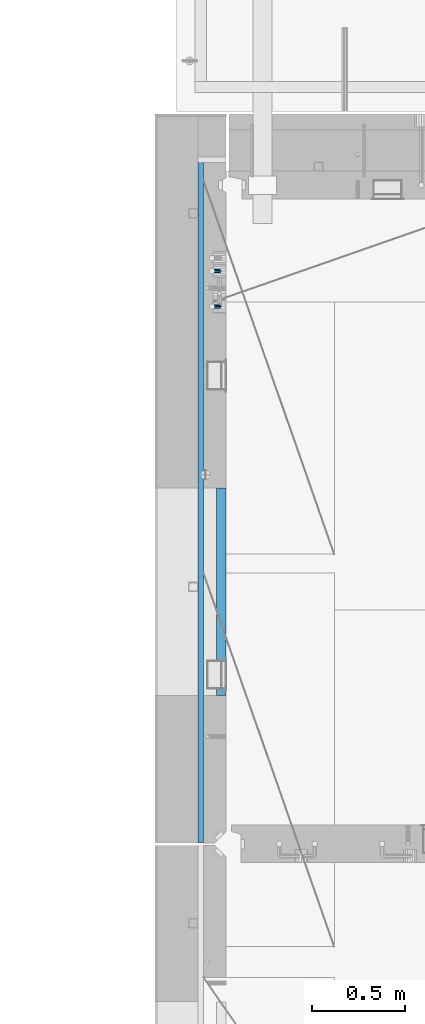
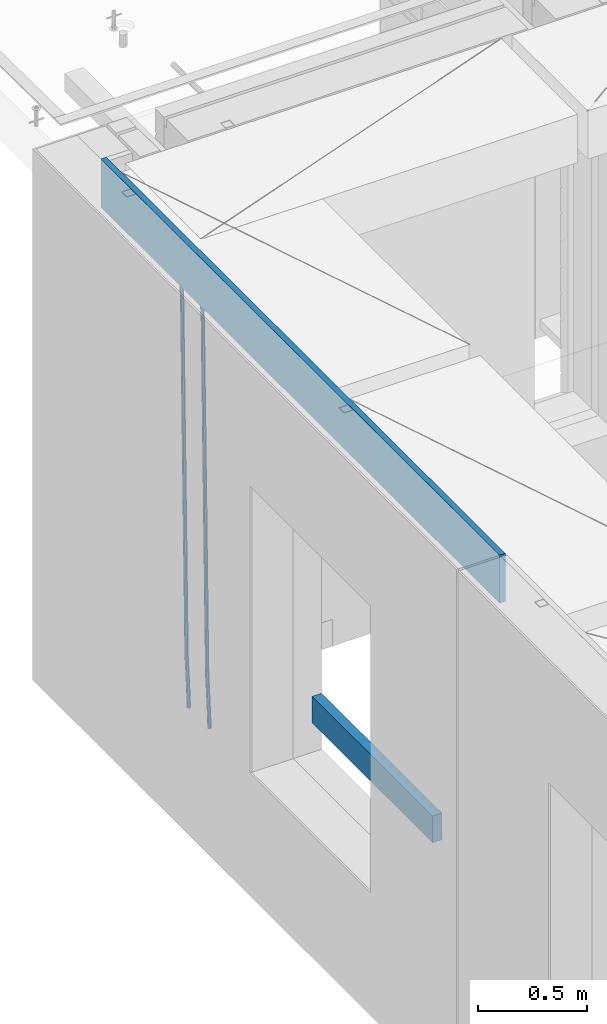
# One storey, part 113 of 349: 4 beams, 1 element without a shape of its own.
"""IFC2X3 building model written with IfcOpenShell, lengths in millimetres."""

import ifcopenshell
import ifcopenshell.guid

model = None  # the IFC model being written
_history = None  # IfcOwnerHistory: only IFC2X3 demands one
_inside = {}  # id of a spatial element -> (the spatial element, [elements in it])
_under = {}  # id of a project, library or spatial element -> (it, [spatial elements below it])
_declared = {}  # id of a project -> (the project, [libraries it declares])
_typed = {}  # id of a type object -> (the type object, [elements of that type])
_made_of = {}  # id of a material, layer set ... -> (it, [elements and type objects made of it])


def new_model(schema):
    """Start an empty IFC model of exactly this schema.

    Asked for "IFC4X3", IfcOpenShell would pick the latest addendum, in which some entities
    have other attributes; the version numbers below select the first issue.
    IFC2X3 requires an IfcOwnerHistory on every rooted entity: one is made here for all.
    """
    global model, _history
    if schema == "IFC4X3":
        model = ifcopenshell.file(schema_version=(4, 3, 0, 0))
    else:
        model = ifcopenshell.file(schema=schema)
    _inside.clear()
    _under.clear()
    _declared.clear()
    _typed.clear()
    _made_of.clear()
    _history = None
    if model.schema == "IFC2X3":
        org = make("IfcOrganization", Name="unknown")
        user = make(
            "IfcPersonAndOrganization",
            ThePerson=make("IfcPerson", FamilyName="unknown"),
            TheOrganization=org,
        )
        app = make(
            "IfcApplication",
            ApplicationDeveloper=org,
            Version="unknown",
            ApplicationFullName="unknown",
            ApplicationIdentifier="unknown",
        )
        _history = make(
            "IfcOwnerHistory",
            OwningUser=user,
            OwningApplication=app,
            ChangeAction="ADDED",
            CreationDate=0,
        )
    return model


def make(cls, **values):
    """One entity of the class cls with the attributes given. An attribute that is None is left unset."""
    return model.create_entity(
        cls, **{name: value for name, value in values.items() if value is not None}
    )


def rooted(cls, **values):
    """An entity with a GlobalId (a new one), such as an element, a storey or a relation."""
    return make(cls, GlobalId=ifcopenshell.guid.new(), OwnerHistory=_history, **values)


def si_unit(unit_type, name, prefix=None):
    """IfcSIUnit, for example si_unit("LENGTHUNIT", "METRE", prefix="MILLI")."""
    return make("IfcSIUnit", UnitType=unit_type, Prefix=prefix, Name=name)


def assignment(units):
    """IfcUnitAssignment: the units of a project."""
    return None if units is None else make("IfcUnitAssignment", Units=units)


def point(xyz):
    """IfcCartesianPoint."""
    return None if xyz is None else make("IfcCartesianPoint", Coordinates=xyz)


def direction(xyz):
    """IfcDirection."""
    return None if xyz is None else make("IfcDirection", DirectionRatios=xyz)


def frame(location, z_axis=None, x_axis=None):
    """IfcAxis2Placement3D, a coordinate frame: its origin and axes. An axis left out is left unset."""
    return make(
        "IfcAxis2Placement3D",
        Location=point(location),
        Axis=direction(z_axis),
        RefDirection=direction(x_axis),
    )


def origin_with_axes():
    """The frame at (0, 0, 0) with the z axis (0, 0, 1) and the x axis (1, 0, 0) written out."""
    return frame((0.0, 0.0, 0.0), z_axis=(0.0, 0.0, 1.0), x_axis=(1.0, 0.0, 0.0))


def place(relative_to, where):
    """IfcLocalPlacement: puts the frame where relative to a parent placement (None: the world)."""
    return make(
        "IfcLocalPlacement", PlacementRelTo=relative_to, RelativePlacement=where
    )


def context(
    kind, dimensions, precision=None, world=None, true_north=None, identifier=None
):
    """IfcGeometricRepresentationContext, for example the 3D "Model" context."""
    return make(
        "IfcGeometricRepresentationContext",
        ContextIdentifier=identifier,
        ContextType=kind,
        CoordinateSpaceDimension=dimensions,
        Precision=precision,
        WorldCoordinateSystem=world,
        TrueNorth=true_north,
    )


def subcontext(parent, identifier, kind, view, scale=None):
    """IfcGeometricRepresentationSubContext, for example "Body" below "Model"."""
    return make(
        "IfcGeometricRepresentationSubContext",
        ContextIdentifier=identifier,
        ContextType=kind,
        ParentContext=parent,
        TargetScale=scale,
        TargetView=view,
    )


def project(units=None, contexts=None):
    """IfcProject with its units and contexts."""
    return rooted(
        "IfcProject",
        Name="project",
        RepresentationContexts=contexts,
        UnitsInContext=assignment(units),
    )


def spatial(cls, under=None, at=None, **own):
    """A site, building, storey or space (cls), placed at a placement, below another one or the project."""
    s = rooted(cls, ObjectPlacement=at, **own)
    if under is not None:
        _under.setdefault(under.id(), (under, []))[1].append(s)
    return s


def faces_of(points, faces, orient=None, outer=None):
    """IfcFace entities. A face is a list of loops; a loop is a list of indices into points, from 0.

    orient and outer hold one flag for each loop. By default every Orientation is true, the
    first loop of a face is its IfcFaceOuterBound and the others are IfcFaceBound.
    """
    made = []
    for i, loops in enumerate(faces):
        bounds = []
        for j, loop in enumerate(loops):
            is_outer = j == 0 if outer is None else outer[i][j]
            bounds.append(
                make(
                    "IfcFaceOuterBound" if is_outer else "IfcFaceBound",
                    Bound=make("IfcPolyLoop", Polygon=[points[k] for k in loop]),
                    Orientation=True if orient is None else orient[i][j],
                )
            )
        made.append(make("IfcFace", Bounds=bounds))
    return made


def faceted_brep(points, faces, orient=None, outer=None, voids=None):
    """IfcFacetedBrep: a solid bounded by flat faces; with voids (closed shells), ...WithVoids."""
    shared = [point(p) for p in points]
    hull = make("IfcClosedShell", CfsFaces=faces_of(shared, faces, orient, outer))
    if voids is None:
        return make("IfcFacetedBrep", Outer=hull)
    return make(
        "IfcFacetedBrepWithVoids",
        Outer=hull,
        Voids=[
            make(cls, CfsFaces=faces_of(shared, fs, o, b)) for cls, fs, o, b in voids
        ],
    )


def shape(context_of_items, identifier, shape_type, items):
    """IfcShapeRepresentation: the items that make up one representation, for example the "Body"."""
    return make(
        "IfcShapeRepresentation",
        ContextOfItems=context_of_items,
        RepresentationIdentifier=identifier,
        RepresentationType=shape_type,
        Items=items,
    )


def material(Name=None, Category=None):
    """IfcMaterial."""
    return make("IfcMaterial", Name=Name, Category=Category)


def made_of(thing, what):
    """Note that an element or type object is made of a material, layer set ...; save() writes the relation."""
    if what is not None:
        _made_of.setdefault(what.id(), (what, []))[1].append(thing)
    return thing


def type_object(cls, material=None, **own):
    """A type object (cls), such as IfcWallType, which elements share."""
    return made_of(rooted(cls, **own), material)


def element(
    cls,
    number,
    at=None,
    inside=None,
    cuts=None,
    type_object=None,
    material=None,
    context=None,
    identifier="Body",
    shape_type=None,
    held_by="IfcProductDefinitionShape",
    body=None,
    shapes=None,
    **own,
):
    """One element of the class cls, such as IfcWall. Its Tag is "e" and its number.

    at: its placement. inside: the storey or other place that contains it. cuts: it is an
    opening in that element (IfcRelVoidsElement). A single representation is given by context,
    identifier, shape_type and body (its items); several are given by shapes. held_by: the class
    of the entity that holds the representations. save() writes the other relations.
    """
    e = rooted(cls, Tag="e%d" % number, ObjectPlacement=at, **own)
    if body is not None:
        shapes = [shape(context, identifier, shape_type, body)]
    if shapes is not None:
        e.Representation = make(held_by, Representations=shapes)
    if inside is not None:
        _inside.setdefault(inside.id(), (inside, []))[1].append(e)
    if cuts is not None:
        rooted(
            "IfcRelVoidsElement", RelatingBuildingElement=cuts, RelatedOpeningElement=e
        )
    if type_object is not None:
        _typed.setdefault(type_object.id(), (type_object, []))[1].append(e)
    return made_of(e, material)


def aggregate(whole, parts):
    """IfcRelAggregates: a whole, such as a stair, and the parts it consists of."""
    return rooted("IfcRelAggregates", RelatingObject=whole, RelatedObjects=parts)


def save(model, path):
    """Write the relations noted so far, then the file.

    IfcRelAggregates (storeys below a building ...), IfcRelContainedInSpatialStructure (elements
    in a storey), IfcRelDefinesByType, IfcRelAssociatesMaterial and IfcRelDeclares: one each for
    every whole, place, type object, material and project.
    """
    for whole, parts in _under.values():
        aggregate(whole, parts)
    for where, things in _inside.values():
        rooted(
            "IfcRelContainedInSpatialStructure",
            RelatedElements=things,
            RelatingStructure=where,
        )
    for kind, things in _typed.values():
        rooted("IfcRelDefinesByType", RelatedObjects=things, RelatingType=kind)
    for what, things in _made_of.values():
        rooted("IfcRelAssociatesMaterial", RelatedObjects=things, RelatingMaterial=what)
    for by, libraries in _declared.values():
        rooted("IfcRelDeclares", RelatingContext=by, RelatedDefinitions=libraries)
    model.write(path)


model = new_model("IFC2X3")

# Units and contexts
model_context = context("Model", 3, precision=1e-05, world=origin_with_axes())
body_context = subcontext(model_context, "Body", "Model", "MODEL_VIEW")
ifc_project = project(units=[si_unit("LENGTHUNIT", "METRE", prefix="MILLI"), si_unit("AREAUNIT", "SQUARE_METRE"), si_unit("VOLUMEUNIT", "CUBIC_METRE"), si_unit("MASSUNIT", "GRAM", prefix="KILO"), si_unit("TIMEUNIT", "SECOND"), si_unit("PLANEANGLEUNIT", "RADIAN"), si_unit("SOLIDANGLEUNIT", "STERADIAN"), si_unit("THERMODYNAMICTEMPERATUREUNIT", "DEGREE_CELSIUS"), si_unit("LUMINOUSINTENSITYUNIT", "LUMEN")], contexts=[model_context])

# Site, building, storey
site_placement = place(None, origin_with_axes())
site = spatial("IfcSite", under=ifc_project, at=site_placement, CompositionType="ELEMENT")
building_placement = place(site_placement, origin_with_axes())
building = spatial("IfcBuilding", under=site, at=building_placement, CompositionType="ELEMENT")
storey_placement = place(building_placement, origin_with_axes())
storey = spatial("IfcBuildingStorey", under=building, at=storey_placement, Name="4", CompositionType="ELEMENT", Elevation=0.0)

# Assembly, beams
assembly_placement = place(storey_placement, origin_with_axes())
assembly = element("IfcElementAssembly", 1, at=assembly_placement, inside=storey, AssemblyPlace="NOTDEFINED", PredefinedType="REINFORCEMENT_UNIT")
ifc_material_1 = material()
beam_type_1 = type_object("IfcBeamType", Name="D20", PredefinedType="NOTDEFINED")
beam_1_placement = place(assembly_placement, frame((7965.00000227913, 19854.9969072611, 90990.0), z_axis=(-0.999642804636942, -0.000205726999925762, -0.0267249099902983), x_axis=(-0.0267249099948371, 4.30000201934385e-08, 0.999642825806181)))
beam_1 = element("IfcBeam", 2, at=beam_1_placement, type_object=beam_type_1, material=ifc_material_1, Name="JM20", ObjectType="D20", context=body_context, shape_type="Brep", body=[
    faceted_brep([(0.0, -10.0, 0.0), (-4.19531716033816e-08, -7.07106781186667, -7.07106781187031), (60.4266690400545, -7.0710677960451, -7.07106780570757), (60.4266690441291, -9.99999998418934, 6.15546014159918e-09), (0.0, 0.0, -10.0), (60.426669036824, 1.58106558956206e-08, -9.99999999384454), (4.196772351861e-08, 7.07106781186303, -7.07106781186667), (60.4266690363438, 7.07106782768096, -7.07106780570757), (0.0, 10.0, 0.0), (60.4266690388904, 10.0000000158179, 6.15182216279209e-09), (4.196772351861e-08, 7.07106781185939, 7.07106781185939), (60.4266690429649, 7.07106782768096, 7.07106781802577), (0.0, 0.0, 10.0), (60.4266690461809, 1.58179318532348e-08, 10.0000000061555), (-4.19531716033816e-08, -7.07106781187031, 7.07106781185939), (60.4266690466611, -7.07106779605238, 7.07106781802213), (61.0378400410118, -7.07106779588503, -7.07106780564936), (60.991799419251, -9.99999998403655, 6.21366780251265e-09), (61.0569027789461, 1.5985278878361e-08, -9.99999999378269), (61.0378209396877, 7.07106782784831, -7.07106780564936), (60.9917724058905, 10.0000000159635, 6.21366780251265e-09), (60.9457317841297, 7.07106782781193, 7.0710678180767), (60.9266690461809, 1.59488990902901e-08, 10.0000000062028), (60.9457508854539, -7.07106779591413, 7.0710678180767), (61.6489592143771, -7.07106614513759, -7.06310863441468), (61.5568818710308, -9.9999984576425, 0.00735959856683621), (61.6870830769039, 1.71821739058942e-06, -9.99179257185824), (61.6489210170112, 7.07106947854481, -7.06310888312146), (61.556827851804, 10.0000015422847, 0.00735924683976918), (61.4647505084577, 7.07106922979438, 7.07782747982128), (61.4266266459163, 1.36643211590126e-06, 10.0065114172685), (61.464788705809, -7.07106639389531, 7.07782772852806), (176.543135720174, -7.07075579406956, -5.56673531796696), (176.451058376813, -9.99968810657447, 1.50373291501455), (176.581259582701, 0.000312069292704109, -8.49541925541052), (176.543097522794, 7.07137982961285, -5.56673556667374), (176.451004357587, 10.00031189336, 1.50373256329476), (176.35892701424, 7.07137958085514, 8.57420079627263), (176.320803151699, 0.000311717507429421, 11.5028847337162), (176.358965211621, -7.07075604281999, 8.57420104497578), (177.098753836006, -7.07075429323595, -5.55949898843028), (176.98362511232, -9.99968666800123, 1.510669025065), (177.146421932586, 0.000313595905026887, -8.48805862247536), (177.098706077581, 7.07138133041735, -5.55949936166144), (176.983557571715, 10.0003133318824, 1.51066849724157), (176.868428848029, 7.07138095712435, 8.58083651073321), (176.820760751449, 0.000313067976094317, 11.5093961447819), (176.868476606425, -7.07075466652896, 8.58083688396073), (177.654312950661, -7.07075204110879, -5.54863964998367), (177.516135294456, -9.99968450931192, 1.52107783331303), (177.711524267797, 0.000315886711177882, -8.47701274570863), (177.654255632195, 7.07138358250813, -5.54864021007961), (177.516054233929, 10.0003154905207, 1.5210770412159), (177.377876577739, 7.0713830223176, 8.59079452451624), (177.320665260588, 0.000315094497636892, 11.5191676202448), (177.377933896176, -7.07075260129932, 8.59079508461218), (299.436796249574, -7.07025836271714, -3.1681962331204), (299.298618593355, -9.99919083092027, 3.90152125031091), (299.494007566798, 0.000809565110102994, -6.09656932889993), (299.436738931283, 7.07187726089978, -3.16819679320906), (299.298537533061, 10.0008091689197, 3.90152045822106), (299.160359876842, 7.07187670072017, 10.9712379416487), (299.103148559603, 0.000808772889286047, 13.8996110374392), (299.160417195119, -7.07025892290039, 10.9712385017483), (299.98743051647, -7.07025613056248, -3.15743315966392), (299.971788958996, -9.99918809853989, 3.91467979818117), (299.993912075952, 0.000811591617093654, -6.08679785393178), (299.987423933868, 7.07187949325817, -3.1574327280432), (299.971753863239, 10.0008119014747, 3.91467990454839), (299.95611230444, 7.07187992653053, 10.9867922621015), (299.949630744944, 0.000812204350950196, 13.9161569563694), (299.956118887014, -7.07025569729012, 10.9867918304735), (300.538107039494, -7.07025785017686, -3.16575821840888), (300.644985195438, -9.99919020432935, 3.90450175465594), (300.493854948218, 0.000810030429420294, -6.09435592770024), (300.538151196495, 7.071877773491, -3.16575855385963), (300.645047642858, 10.0008097955724, 3.90450128024895), (300.751925798773, 7.07187744142357, 10.9747612533101), (300.796177890064, 0.000809560813650023, 13.9033589625978), (300.751881641787, -7.07025818224065, 10.9747615887682), (2293.36490490142, -7.07648090940347, -33.2930642912361), (2293.47178305736, -10.0054132635523, -26.2228043181785), (2293.32065281013, -0.00541302880083094, -36.2216620005347), (2293.36494905842, 7.06565471425711, -33.2930646266868), (2293.47184550477, 9.99458673634581, -26.2228047925819), (2293.57872366071, 7.06565438219332, -19.1525448195243), (2293.62297575199, -0.00541349841296324, -16.2239471102366), (2293.57867950371, -7.0764812414709, -19.1525444840736), (2294.0658245362, -7.07648309818615, -33.3036607065333), (2294.05312277409, -10.0054150789219, -26.2315929392535), (2294.10928714235, -0.00541549149056664, -36.2335844756526), (2294.15805078732, 7.06565223761572, -33.3050546393533), (2294.18355038921, 9.99458451388637, -26.2335642579346), (2294.17084862708, 7.06565253314329, -19.1614964906439), (2294.12738602093, -0.00541507354500936, -16.2315727215355), (2294.07862237596, -7.07648280265857, -19.1601025578348), (2294.76670261032, -7.08562269121467, -33.294332712383), (2294.63442802057, -10.0129954178956, -26.2238563411993), (2294.89787471293, -0.0156988342423574, -36.2230891548279), (2294.95110548967, 7.05531064255774, -33.2944998654275), (2294.89521307347, 9.98530428734011, -26.2240927312887), (2294.76293848372, 7.0579315606592, -19.1536163601049), (2294.63176638114, -0.0119922963167483, -16.2248599176673), (2294.57853560438, -7.08300177311321, -19.1534492070678), (2316.52657204497, -7.36937582653991, -33.0047303660212), (2316.39429745522, -10.2967485532172, -25.9342539948302), (2316.65774414754, -0.299451969567599, -35.9334868084661), (2316.7109749243, 6.7715575072325, -33.0048975190657), (2316.65508250811, 9.70155115201487, -25.9344903849269), (2316.52280791836, 6.7741784253376, -18.8640140137468), (2316.39163581574, -0.295745431634714, -15.9352575713092), (2316.33840503903, -7.36675490843481, -18.863846860706), (2317.16202064224, -7.37766220584308, -32.9962731735213), (2317.05438744847, -10.3053562613532, -25.9254688497131), (2317.23607125619, -0.306993473008333, -35.925789846493), (2317.23316144495, 6.76474808850253, -32.9979477328052), (2317.15499573652, 9.6950321815566, -25.9278370341635), (2317.04736254275, 6.7673381260538, -18.8570327103698), (2316.97331192881, -0.303330606784584, -15.9275160373909), (2316.97622174003, -7.37507216829545, -18.8553581510787), (2317.79752306276, -7.37578610372293, -32.9880110666527), (2317.71453320107, -10.3033876998124, -25.9168792378296), (2317.81444760226, -0.305295583297266, -35.918287695793), (2317.75539265381, 6.76628640723357, -32.9911928173897), (2317.65495180529, 9.69652304524061, -25.9213789128698), (2317.5719619436, 6.76892144914746, -18.8502470840467), (2317.55503740412, -0.301569071270933, -15.9199704549137), (2317.61409235255, -7.3731510618054, -18.847065333317), (2417.8183084176, -7.07752398473531, -31.6906369377139), (2417.73531855589, -10.0051255808248, -24.6195051088798), (2417.83523295709, -0.007033464313281, -34.6209135668432), (2417.77617800863, 7.06454852621755, -31.6938186884508), (2417.67573716014, 9.99478516423187, -24.6240047839383), (2417.59274729842, 7.06718356813872, -17.5528729551006), (2417.57582275895, -0.00330695228694822, -14.6225963259749), (2417.6348777074, -7.07488894281778, -17.5496912043673)], [[[0, 1, 2, 3]], [[1, 4, 5, 2]], [[4, 6, 7, 5]], [[6, 8, 9, 7]], [[8, 10, 11, 9]], [[10, 12, 13, 11]], [[12, 14, 15, 13]], [[14, 0, 3, 15]], [[14, 12, 10, 8, 6, 4, 1, 0]], [[3, 2, 16, 17]], [[2, 5, 18, 16]], [[5, 7, 19, 18]], [[7, 9, 20, 19]], [[9, 11, 21, 20]], [[11, 13, 22, 21]], [[13, 15, 23, 22]], [[15, 3, 17, 23]], [[17, 16, 24, 25]], [[16, 18, 26, 24]], [[18, 19, 27, 26]], [[19, 20, 28, 27]], [[20, 21, 29, 28]], [[21, 22, 30, 29]], [[22, 23, 31, 30]], [[23, 17, 25, 31]], [[25, 24, 32, 33]], [[24, 26, 34, 32]], [[26, 27, 35, 34]], [[27, 28, 36, 35]], [[28, 29, 37, 36]], [[29, 30, 38, 37]], [[30, 31, 39, 38]], [[31, 25, 33, 39]], [[33, 32, 40, 41]], [[32, 34, 42, 40]], [[34, 35, 43, 42]], [[35, 36, 44, 43]], [[36, 37, 45, 44]], [[37, 38, 46, 45]], [[38, 39, 47, 46]], [[39, 33, 41, 47]], [[41, 40, 48, 49]], [[40, 42, 50, 48]], [[42, 43, 51, 50]], [[43, 44, 52, 51]], [[44, 45, 53, 52]], [[45, 46, 54, 53]], [[46, 47, 55, 54]], [[47, 41, 49, 55]], [[49, 48, 56, 57]], [[48, 50, 58, 56]], [[50, 51, 59, 58]], [[51, 52, 60, 59]], [[52, 53, 61, 60]], [[53, 54, 62, 61]], [[54, 55, 63, 62]], [[55, 49, 57, 63]], [[57, 56, 64, 65]], [[56, 58, 66, 64]], [[58, 59, 67, 66]], [[59, 60, 68, 67]], [[60, 61, 69, 68]], [[61, 62, 70, 69]], [[62, 63, 71, 70]], [[63, 57, 65, 71]], [[65, 64, 72, 73]], [[64, 66, 74, 72]], [[66, 67, 75, 74]], [[67, 68, 76, 75]], [[68, 69, 77, 76]], [[69, 70, 78, 77]], [[70, 71, 79, 78]], [[71, 65, 73, 79]], [[73, 72, 80, 81]], [[72, 74, 82, 80]], [[74, 75, 83, 82]], [[75, 76, 84, 83]], [[76, 77, 85, 84]], [[77, 78, 86, 85]], [[78, 79, 87, 86]], [[79, 73, 81, 87]], [[81, 80, 88, 89]], [[80, 82, 90, 88]], [[82, 83, 91, 90]], [[83, 84, 92, 91]], [[84, 85, 93, 92]], [[85, 86, 94, 93]], [[86, 87, 95, 94]], [[87, 81, 89, 95]], [[89, 88, 96, 97]], [[88, 90, 98, 96]], [[90, 91, 99, 98]], [[91, 92, 100, 99]], [[92, 93, 101, 100]], [[93, 94, 102, 101]], [[94, 95, 103, 102]], [[95, 89, 97, 103]], [[97, 96, 104, 105]], [[96, 98, 106, 104]], [[98, 99, 107, 106]], [[99, 100, 108, 107]], [[100, 101, 109, 108]], [[101, 102, 110, 109]], [[102, 103, 111, 110]], [[103, 97, 105, 111]], [[105, 104, 112, 113]], [[104, 106, 114, 112]], [[106, 107, 115, 114]], [[107, 108, 116, 115]], [[108, 109, 117, 116]], [[109, 110, 118, 117]], [[110, 111, 119, 118]], [[111, 105, 113, 119]], [[113, 112, 120, 121]], [[112, 114, 122, 120]], [[114, 115, 123, 122]], [[115, 116, 124, 123]], [[116, 117, 125, 124]], [[117, 118, 126, 125]], [[118, 119, 127, 126]], [[119, 113, 121, 127]], [[121, 120, 128, 129]], [[120, 122, 130, 128]], [[122, 123, 131, 130]], [[123, 124, 132, 131]], [[124, 125, 133, 132]], [[125, 126, 134, 133]], [[126, 127, 135, 134]], [[127, 121, 129, 135]], [[130, 131, 132, 133, 134, 135, 129, 128]]]),
])
beam_2_placement = place(assembly_placement, frame((7965.00000227913, 20044.9969072611, 90990.0), z_axis=(-0.999642804636942, -0.000205726999925762, -0.0267249099902983), x_axis=(-0.0267249099948371, 4.30000201934385e-08, 0.999642825806181)))
beam_2 = element("IfcBeam", 3, at=beam_2_placement, type_object=beam_type_1, material=ifc_material_1, Name="JM20", ObjectType="D20", context=body_context, shape_type="Brep", body=[
    faceted_brep([(0.0, -10.0, 0.0), (-4.19531716033816e-08, -7.07106781186667, -7.07106781187031), (60.4266690400545, -7.0710677960451, -7.07106780570757), (60.4266690441291, -9.99999998418934, 6.15546014159918e-09), (0.0, 0.0, -10.0), (60.426669036824, 1.58106558956206e-08, -9.99999999384454), (4.196772351861e-08, 7.07106781186303, -7.07106781186667), (60.4266690363438, 7.07106782768096, -7.07106780570757), (0.0, 10.0, 0.0), (60.4266690388904, 10.0000000158179, 6.15182216279209e-09), (4.196772351861e-08, 7.07106781185939, 7.07106781185939), (60.4266690429649, 7.07106782768096, 7.07106781802577), (0.0, 0.0, 10.0), (60.4266690461809, 1.58179318532348e-08, 10.0000000061555), (-4.19531716033816e-08, -7.07106781187031, 7.07106781185939), (60.4266690466611, -7.07106779605238, 7.07106781802213), (61.0378400410118, -7.07106779588503, -7.07106780564936), (60.991799419251, -9.99999998403655, 6.21366780251265e-09), (61.0569027789461, 1.5985278878361e-08, -9.99999999378269), (61.0378209396877, 7.07106782784831, -7.07106780564936), (60.9917724058905, 10.0000000159635, 6.21366780251265e-09), (60.9457317841297, 7.07106782781193, 7.0710678180767), (60.9266690461809, 1.59488990902901e-08, 10.0000000062028), (60.9457508854539, -7.07106779591413, 7.0710678180767), (61.6489592143771, -7.07106614513759, -7.06310863441468), (61.5568818710308, -9.9999984576425, 0.00735959856683621), (61.6870830769039, 1.71821739058942e-06, -9.99179257185824), (61.6489210170112, 7.07106947854481, -7.06310888312146), (61.556827851804, 10.0000015422847, 0.00735924683976918), (61.4647505084577, 7.07106922979438, 7.07782747982128), (61.4266266459163, 1.36643211590126e-06, 10.0065114172685), (61.464788705809, -7.07106639389531, 7.07782772852806), (176.543135720174, -7.07075579406956, -5.56673531796696), (176.451058376813, -9.99968810657447, 1.50373291501455), (176.581259582701, 0.000312069292704109, -8.49541925541052), (176.543097522794, 7.07137982961285, -5.56673556667374), (176.451004357587, 10.00031189336, 1.50373256329476), (176.35892701424, 7.07137958085514, 8.57420079627263), (176.320803151699, 0.000311717507429421, 11.5028847337162), (176.358965211621, -7.07075604281999, 8.57420104497578), (177.098753836006, -7.07075429323595, -5.55949898843028), (176.98362511232, -9.99968666800123, 1.510669025065), (177.146421932586, 0.000313595905026887, -8.48805862247536), (177.098706077581, 7.07138133041735, -5.55949936166144), (176.983557571715, 10.0003133318824, 1.51066849724157), (176.868428848029, 7.07138095712435, 8.58083651073321), (176.820760751449, 0.000313067976094317, 11.5093961447819), (176.868476606425, -7.07075466652896, 8.58083688396073), (177.654312950661, -7.07075204110879, -5.54863964998367), (177.516135294456, -9.99968450931192, 1.52107783331303), (177.711524267797, 0.000315886711177882, -8.47701274570863), (177.654255632195, 7.07138358250813, -5.54864021007961), (177.516054233929, 10.0003154905207, 1.5210770412159), (177.377876577739, 7.0713830223176, 8.59079452451624), (177.320665260588, 0.000315094497636892, 11.5191676202448), (177.377933896176, -7.07075260129932, 8.59079508461218), (299.436796249574, -7.07025836271714, -3.1681962331204), (299.298618593355, -9.99919083092027, 3.90152125031091), (299.494007566798, 0.000809565110102994, -6.09656932889993), (299.436738931283, 7.07187726089978, -3.16819679320906), (299.298537533061, 10.0008091689197, 3.90152045822106), (299.160359876842, 7.07187670072017, 10.9712379416487), (299.103148559603, 0.000808772889286047, 13.8996110374392), (299.160417195119, -7.07025892290039, 10.9712385017483), (299.98743051647, -7.07025613056248, -3.15743315966392), (299.971788958996, -9.99918809853989, 3.91467979818117), (299.993912075952, 0.000811591617093654, -6.08679785393178), (299.987423933868, 7.07187949325817, -3.1574327280432), (299.971753863239, 10.0008119014747, 3.91467990454839), (299.95611230444, 7.07187992653053, 10.9867922621015), (299.949630744944, 0.000812204350950196, 13.9161569563694), (299.956118887014, -7.07025569729012, 10.9867918304735), (300.538107039494, -7.07025785017686, -3.16575821840888), (300.644985195438, -9.99919020432935, 3.90450175465594), (300.493854948218, 0.000810030429420294, -6.09435592770024), (300.538151196495, 7.071877773491, -3.16575855385963), (300.645047642858, 10.0008097955724, 3.90450128024895), (300.751925798773, 7.07187744142357, 10.9747612533101), (300.796177890064, 0.000809560813650023, 13.9033589625978), (300.751881641787, -7.07025818224065, 10.9747615887682), (2293.36490490142, -7.07648090940347, -33.2930642912361), (2293.47178305736, -10.0054132635523, -26.2228043181785), (2293.32065281013, -0.00541302880083094, -36.2216620005347), (2293.36494905842, 7.06565471425711, -33.2930646266868), (2293.47184550477, 9.99458673634581, -26.2228047925819), (2293.57872366071, 7.06565438219332, -19.1525448195243), (2293.62297575199, -0.00541349841296324, -16.2239471102366), (2293.57867950371, -7.0764812414709, -19.1525444840736), (2294.0658245362, -7.07648309818615, -33.3036607065333), (2294.05312277409, -10.0054150789219, -26.2315929392535), (2294.10928714235, -0.00541549149056664, -36.2335844756526), (2294.15805078732, 7.06565223761572, -33.3050546393533), (2294.18355038921, 9.99458451388637, -26.2335642579346), (2294.17084862708, 7.06565253314329, -19.1614964906439), (2294.12738602093, -0.00541507354500936, -16.2315727215355), (2294.07862237596, -7.07648280265857, -19.1601025578348), (2294.76670261032, -7.08562269121467, -33.294332712383), (2294.63442802057, -10.0129954178956, -26.2238563411993), (2294.89787471293, -0.0156988342423574, -36.2230891548279), (2294.95110548967, 7.05531064255774, -33.2944998654275), (2294.89521307347, 9.98530428734011, -26.2240927312887), (2294.76293848372, 7.0579315606592, -19.1536163601049), (2294.63176638114, -0.0119922963167483, -16.2248599176673), (2294.57853560438, -7.08300177311321, -19.1534492070678), (2316.52657204497, -7.36937582653991, -33.0047303660212), (2316.39429745522, -10.2967485532172, -25.9342539948302), (2316.65774414754, -0.299451969567599, -35.9334868084661), (2316.7109749243, 6.7715575072325, -33.0048975190657), (2316.65508250811, 9.70155115201487, -25.9344903849269), (2316.52280791836, 6.7741784253376, -18.8640140137468), (2316.39163581574, -0.295745431634714, -15.9352575713092), (2316.33840503903, -7.36675490843481, -18.863846860706), (2317.16202064224, -7.37766220584308, -32.9962731735213), (2317.05438744847, -10.3053562613532, -25.9254688497131), (2317.23607125619, -0.306993473008333, -35.925789846493), (2317.23316144495, 6.76474808850253, -32.9979477328052), (2317.15499573652, 9.6950321815566, -25.9278370341635), (2317.04736254275, 6.7673381260538, -18.8570327103698), (2316.97331192881, -0.303330606784584, -15.9275160373909), (2316.97622174003, -7.37507216829545, -18.8553581510787), (2317.79752306276, -7.37578610372293, -32.9880110666527), (2317.71453320107, -10.3033876998124, -25.9168792378296), (2317.81444760226, -0.305295583297266, -35.918287695793), (2317.75539265381, 6.76628640723357, -32.9911928173897), (2317.65495180529, 9.69652304524061, -25.9213789128698), (2317.5719619436, 6.76892144914746, -18.8502470840467), (2317.55503740412, -0.301569071270933, -15.9199704549137), (2317.61409235255, -7.3731510618054, -18.847065333317), (2417.8183084176, -7.07752398473531, -31.6906369377139), (2417.73531855589, -10.0051255808248, -24.6195051088798), (2417.83523295709, -0.007033464313281, -34.6209135668432), (2417.77617800863, 7.06454852621755, -31.6938186884508), (2417.67573716014, 9.99478516423187, -24.6240047839383), (2417.59274729842, 7.06718356813872, -17.5528729551006), (2417.57582275895, -0.00330695228694822, -14.6225963259749), (2417.6348777074, -7.07488894281778, -17.5496912043673)], [[[0, 1, 2, 3]], [[1, 4, 5, 2]], [[4, 6, 7, 5]], [[6, 8, 9, 7]], [[8, 10, 11, 9]], [[10, 12, 13, 11]], [[12, 14, 15, 13]], [[14, 0, 3, 15]], [[14, 12, 10, 8, 6, 4, 1, 0]], [[3, 2, 16, 17]], [[2, 5, 18, 16]], [[5, 7, 19, 18]], [[7, 9, 20, 19]], [[9, 11, 21, 20]], [[11, 13, 22, 21]], [[13, 15, 23, 22]], [[15, 3, 17, 23]], [[17, 16, 24, 25]], [[16, 18, 26, 24]], [[18, 19, 27, 26]], [[19, 20, 28, 27]], [[20, 21, 29, 28]], [[21, 22, 30, 29]], [[22, 23, 31, 30]], [[23, 17, 25, 31]], [[25, 24, 32, 33]], [[24, 26, 34, 32]], [[26, 27, 35, 34]], [[27, 28, 36, 35]], [[28, 29, 37, 36]], [[29, 30, 38, 37]], [[30, 31, 39, 38]], [[31, 25, 33, 39]], [[33, 32, 40, 41]], [[32, 34, 42, 40]], [[34, 35, 43, 42]], [[35, 36, 44, 43]], [[36, 37, 45, 44]], [[37, 38, 46, 45]], [[38, 39, 47, 46]], [[39, 33, 41, 47]], [[41, 40, 48, 49]], [[40, 42, 50, 48]], [[42, 43, 51, 50]], [[43, 44, 52, 51]], [[44, 45, 53, 52]], [[45, 46, 54, 53]], [[46, 47, 55, 54]], [[47, 41, 49, 55]], [[49, 48, 56, 57]], [[48, 50, 58, 56]], [[50, 51, 59, 58]], [[51, 52, 60, 59]], [[52, 53, 61, 60]], [[53, 54, 62, 61]], [[54, 55, 63, 62]], [[55, 49, 57, 63]], [[57, 56, 64, 65]], [[56, 58, 66, 64]], [[58, 59, 67, 66]], [[59, 60, 68, 67]], [[60, 61, 69, 68]], [[61, 62, 70, 69]], [[62, 63, 71, 70]], [[63, 57, 65, 71]], [[65, 64, 72, 73]], [[64, 66, 74, 72]], [[66, 67, 75, 74]], [[67, 68, 76, 75]], [[68, 69, 77, 76]], [[69, 70, 78, 77]], [[70, 71, 79, 78]], [[71, 65, 73, 79]], [[73, 72, 80, 81]], [[72, 74, 82, 80]], [[74, 75, 83, 82]], [[75, 76, 84, 83]], [[76, 77, 85, 84]], [[77, 78, 86, 85]], [[78, 79, 87, 86]], [[79, 73, 81, 87]], [[81, 80, 88, 89]], [[80, 82, 90, 88]], [[82, 83, 91, 90]], [[83, 84, 92, 91]], [[84, 85, 93, 92]], [[85, 86, 94, 93]], [[86, 87, 95, 94]], [[87, 81, 89, 95]], [[89, 88, 96, 97]], [[88, 90, 98, 96]], [[90, 91, 99, 98]], [[91, 92, 100, 99]], [[92, 93, 101, 100]], [[93, 94, 102, 101]], [[94, 95, 103, 102]], [[95, 89, 97, 103]], [[97, 96, 104, 105]], [[96, 98, 106, 104]], [[98, 99, 107, 106]], [[99, 100, 108, 107]], [[100, 101, 109, 108]], [[101, 102, 110, 109]], [[102, 103, 111, 110]], [[103, 97, 105, 111]], [[105, 104, 112, 113]], [[104, 106, 114, 112]], [[106, 107, 115, 114]], [[107, 108, 116, 115]], [[108, 109, 117, 116]], [[109, 110, 118, 117]], [[110, 111, 119, 118]], [[111, 105, 113, 119]], [[113, 112, 120, 121]], [[112, 114, 122, 120]], [[114, 115, 123, 122]], [[115, 116, 124, 123]], [[116, 117, 125, 124]], [[117, 118, 126, 125]], [[118, 119, 127, 126]], [[119, 113, 121, 127]], [[121, 120, 128, 129]], [[120, 122, 130, 128]], [[122, 123, 131, 130]], [[123, 124, 132, 131]], [[124, 125, 133, 132]], [[125, 126, 134, 133]], [[126, 127, 135, 134]], [[127, 121, 129, 135]], [[130, 131, 132, 133, 134, 135, 129, 128]]]),
])
ifc_material_2 = material(Name="TIMBER/T24")
beam_type_2 = type_object("IfcBeamType", PredefinedType="NOTDEFINED")
beam_3_placement = place(assembly_placement, frame((7975.00000026382, 18885.0004107749, 91685.0), z_axis=(0.0, 0.0, 1.0), x_axis=(0.0, -1.0, 0.0)))
beam_3 = element("IfcBeam", 4, at=beam_3_placement, type_object=beam_type_2, material=ifc_material_2, context=body_context, shape_type="Brep", body=[
    faceted_brep([(-3.63797880709171e-12, 24.9999999999964, -75.0), (-3.63797880709171e-12, 24.9999999999964, 75.0), (1110.0, 24.9999999999964, 75.0), (1110.0, 24.9999999999964, -75.0), (0.0, -25.0000000000073, 75.0), (1110.0, -25.0000000000073, 75.0), (0.0, -25.0000000000073, -75.0), (1110.0, -25.0000000000073, -75.0)], [[[0, 1, 2, 3]], [[1, 4, 5, 2]], [[4, 6, 7, 5]], [[6, 0, 3, 7]], [[5, 7, 3, 2]], [[6, 4, 1, 0]]]),
])
ifc_material_3 = material(Name="CONCRETE/C25/30")
beam_type_3 = type_object("IfcBeamType", Name="270X30", PredefinedType="NOTDEFINED")
beam_4_placement = place(assembly_placement, frame((7865.0, 20654.9951872276, 93605.0), z_axis=(0.0, 0.0, 1.0), x_axis=(0.0, -1.0, 0.0)))
beam_4 = element("IfcBeam", 5, at=beam_4_placement, type_object=beam_type_3, material=ifc_material_3, ObjectType="270X30", context=body_context, shape_type="Brep", body=[
    faceted_brep([(0.0, 15.0, -135.0), (0.0, 15.0, 135.0), (3669.99518722759, 15.0, 135.0), (3669.99518722759, 15.0, -135.0), (0.0, -15.0, 135.0), (3669.99518722759, -15.0, 135.0), (0.0, -15.0, -135.0), (3669.99518722759, -15.0, -135.0)], [[[0, 1, 2, 3]], [[1, 4, 5, 2]], [[4, 6, 7, 5]], [[6, 0, 3, 7]], [[5, 7, 3, 2]], [[6, 4, 1, 0]]]),
])
aggregate(assembly, [beam_1, beam_2, beam_4, beam_3])

save(model, "model.ifc")
